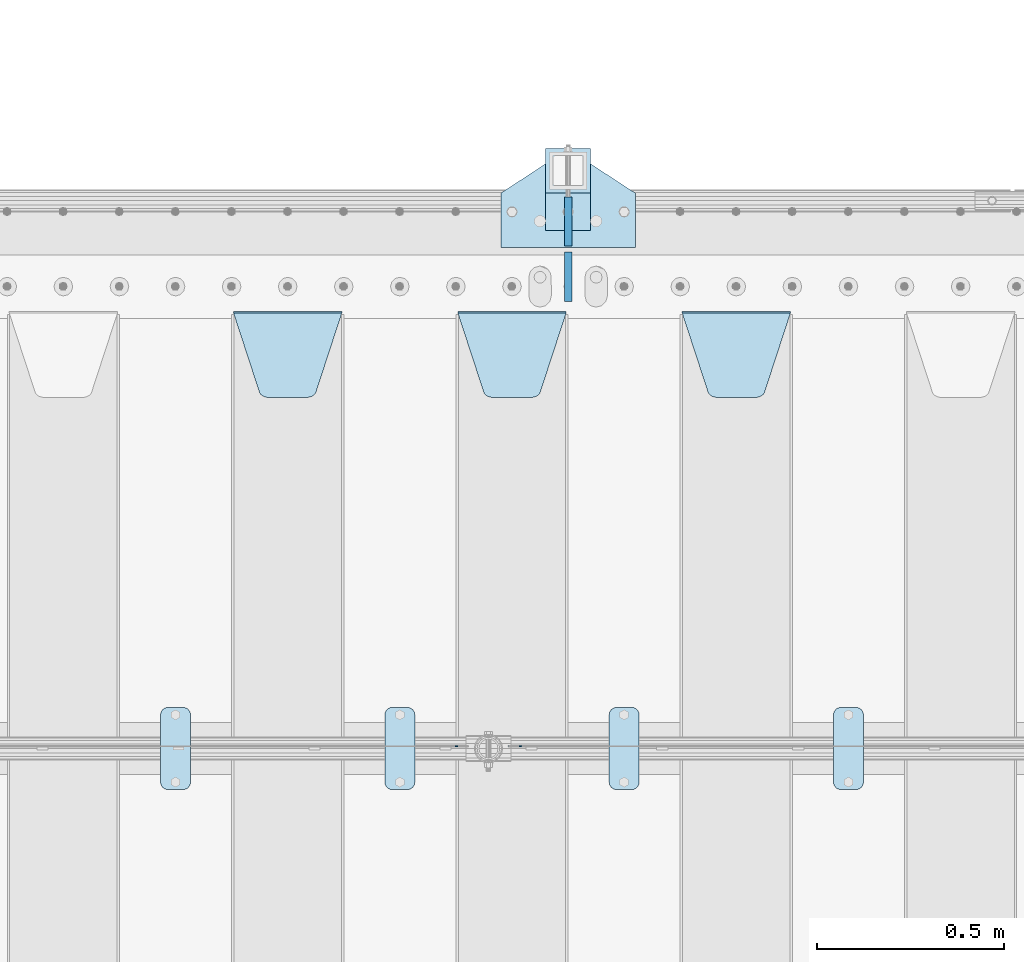
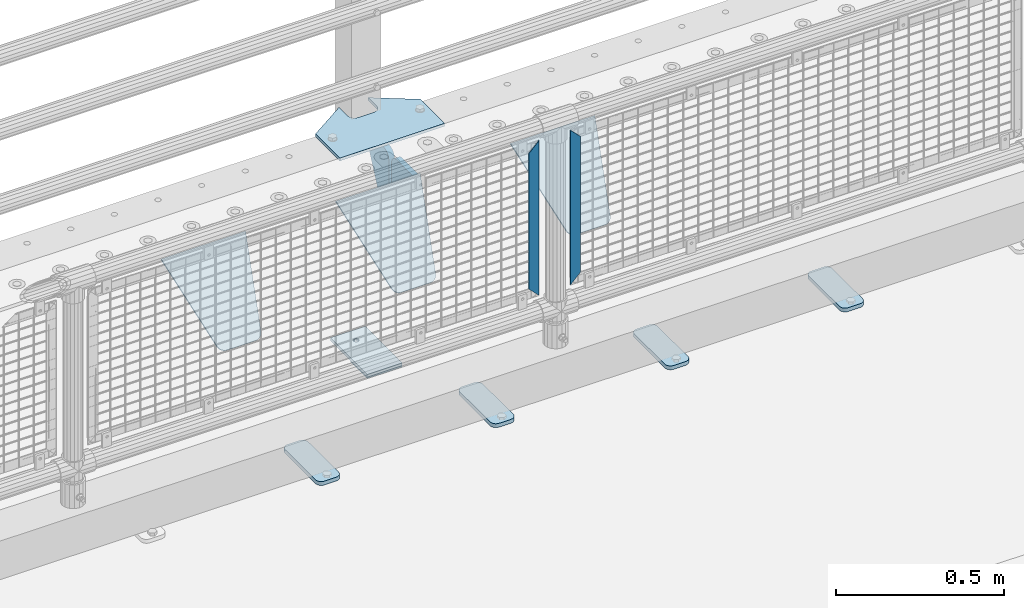
# One storey, part 196 of 219: 14 plates.
"""IFC2X3 building model written with IfcOpenShell, lengths in millimetres."""

import ifcopenshell
import ifcopenshell.guid

model = None  # the IFC model being written
_history = None  # IfcOwnerHistory: only IFC2X3 demands one
_inside = {}  # id of a spatial element -> (the spatial element, [elements in it])
_under = {}  # id of a project, library or spatial element -> (it, [spatial elements below it])
_declared = {}  # id of a project -> (the project, [libraries it declares])
_typed = {}  # id of a type object -> (the type object, [elements of that type])
_made_of = {}  # id of a material, layer set ... -> (it, [elements and type objects made of it])


def new_model(schema):
    """Start an empty IFC model of exactly this schema.

    Asked for "IFC4X3", IfcOpenShell would pick the latest addendum, in which some entities
    have other attributes; the version numbers below select the first issue.
    IFC2X3 requires an IfcOwnerHistory on every rooted entity: one is made here for all.
    """
    global model, _history
    if schema == "IFC4X3":
        model = ifcopenshell.file(schema_version=(4, 3, 0, 0))
    else:
        model = ifcopenshell.file(schema=schema)
    _inside.clear()
    _under.clear()
    _declared.clear()
    _typed.clear()
    _made_of.clear()
    _history = None
    if model.schema == "IFC2X3":
        org = make("IfcOrganization", Name="unknown")
        user = make(
            "IfcPersonAndOrganization",
            ThePerson=make("IfcPerson", FamilyName="unknown"),
            TheOrganization=org,
        )
        app = make(
            "IfcApplication",
            ApplicationDeveloper=org,
            Version="unknown",
            ApplicationFullName="unknown",
            ApplicationIdentifier="unknown",
        )
        _history = make(
            "IfcOwnerHistory",
            OwningUser=user,
            OwningApplication=app,
            ChangeAction="ADDED",
            CreationDate=0,
        )
    return model


def make(cls, **values):
    """One entity of the class cls with the attributes given. An attribute that is None is left unset."""
    return model.create_entity(
        cls, **{name: value for name, value in values.items() if value is not None}
    )


def rooted(cls, **values):
    """An entity with a GlobalId (a new one), such as an element, a storey or a relation."""
    return make(cls, GlobalId=ifcopenshell.guid.new(), OwnerHistory=_history, **values)


def si_unit(unit_type, name, prefix=None):
    """IfcSIUnit, for example si_unit("LENGTHUNIT", "METRE", prefix="MILLI")."""
    return make("IfcSIUnit", UnitType=unit_type, Prefix=prefix, Name=name)


def assignment(units):
    """IfcUnitAssignment: the units of a project."""
    return None if units is None else make("IfcUnitAssignment", Units=units)


def point(xyz):
    """IfcCartesianPoint."""
    return None if xyz is None else make("IfcCartesianPoint", Coordinates=xyz)


def direction(xyz):
    """IfcDirection."""
    return None if xyz is None else make("IfcDirection", DirectionRatios=xyz)


def frame(location, z_axis=None, x_axis=None):
    """IfcAxis2Placement3D, a coordinate frame: its origin and axes. An axis left out is left unset."""
    return make(
        "IfcAxis2Placement3D",
        Location=point(location),
        Axis=direction(z_axis),
        RefDirection=direction(x_axis),
    )


def origin_with_axes():
    """The frame at (0, 0, 0) with the z axis (0, 0, 1) and the x axis (1, 0, 0) written out."""
    return frame((0.0, 0.0, 0.0), z_axis=(0.0, 0.0, 1.0), x_axis=(1.0, 0.0, 0.0))


def place(relative_to, where):
    """IfcLocalPlacement: puts the frame where relative to a parent placement (None: the world)."""
    return make(
        "IfcLocalPlacement", PlacementRelTo=relative_to, RelativePlacement=where
    )


def context(
    kind, dimensions, precision=None, world=None, true_north=None, identifier=None
):
    """IfcGeometricRepresentationContext, for example the 3D "Model" context."""
    return make(
        "IfcGeometricRepresentationContext",
        ContextIdentifier=identifier,
        ContextType=kind,
        CoordinateSpaceDimension=dimensions,
        Precision=precision,
        WorldCoordinateSystem=world,
        TrueNorth=true_north,
    )


def subcontext(parent, identifier, kind, view, scale=None):
    """IfcGeometricRepresentationSubContext, for example "Body" below "Model"."""
    return make(
        "IfcGeometricRepresentationSubContext",
        ContextIdentifier=identifier,
        ContextType=kind,
        ParentContext=parent,
        TargetScale=scale,
        TargetView=view,
    )


def project(units=None, contexts=None):
    """IfcProject with its units and contexts."""
    return rooted(
        "IfcProject",
        Name="project",
        RepresentationContexts=contexts,
        UnitsInContext=assignment(units),
    )


def spatial(cls, under=None, at=None, **own):
    """A site, building, storey or space (cls), placed at a placement, below another one or the project."""
    s = rooted(cls, ObjectPlacement=at, **own)
    if under is not None:
        _under.setdefault(under.id(), (under, []))[1].append(s)
    return s


def faces_of(points, faces, orient=None, outer=None):
    """IfcFace entities. A face is a list of loops; a loop is a list of indices into points, from 0.

    orient and outer hold one flag for each loop. By default every Orientation is true, the
    first loop of a face is its IfcFaceOuterBound and the others are IfcFaceBound.
    """
    made = []
    for i, loops in enumerate(faces):
        bounds = []
        for j, loop in enumerate(loops):
            is_outer = j == 0 if outer is None else outer[i][j]
            bounds.append(
                make(
                    "IfcFaceOuterBound" if is_outer else "IfcFaceBound",
                    Bound=make("IfcPolyLoop", Polygon=[points[k] for k in loop]),
                    Orientation=True if orient is None else orient[i][j],
                )
            )
        made.append(make("IfcFace", Bounds=bounds))
    return made


def faceted_brep(points, faces, orient=None, outer=None, voids=None):
    """IfcFacetedBrep: a solid bounded by flat faces; with voids (closed shells), ...WithVoids."""
    shared = [point(p) for p in points]
    hull = make("IfcClosedShell", CfsFaces=faces_of(shared, faces, orient, outer))
    if voids is None:
        return make("IfcFacetedBrep", Outer=hull)
    return make(
        "IfcFacetedBrepWithVoids",
        Outer=hull,
        Voids=[
            make(cls, CfsFaces=faces_of(shared, fs, o, b)) for cls, fs, o, b in voids
        ],
    )


def shape(context_of_items, identifier, shape_type, items):
    """IfcShapeRepresentation: the items that make up one representation, for example the "Body"."""
    return make(
        "IfcShapeRepresentation",
        ContextOfItems=context_of_items,
        RepresentationIdentifier=identifier,
        RepresentationType=shape_type,
        Items=items,
    )


def material(Name=None, Category=None):
    """IfcMaterial."""
    return make("IfcMaterial", Name=Name, Category=Category)


def made_of(thing, what):
    """Note that an element or type object is made of a material, layer set ...; save() writes the relation."""
    if what is not None:
        _made_of.setdefault(what.id(), (what, []))[1].append(thing)
    return thing


def type_object(cls, material=None, **own):
    """A type object (cls), such as IfcWallType, which elements share."""
    return made_of(rooted(cls, **own), material)


def element(
    cls,
    number,
    at=None,
    inside=None,
    cuts=None,
    type_object=None,
    material=None,
    context=None,
    identifier="Body",
    shape_type=None,
    held_by="IfcProductDefinitionShape",
    body=None,
    shapes=None,
    **own,
):
    """One element of the class cls, such as IfcWall. Its Tag is "e" and its number.

    at: its placement. inside: the storey or other place that contains it. cuts: it is an
    opening in that element (IfcRelVoidsElement). A single representation is given by context,
    identifier, shape_type and body (its items); several are given by shapes. held_by: the class
    of the entity that holds the representations. save() writes the other relations.
    """
    e = rooted(cls, Tag="e%d" % number, ObjectPlacement=at, **own)
    if body is not None:
        shapes = [shape(context, identifier, shape_type, body)]
    if shapes is not None:
        e.Representation = make(held_by, Representations=shapes)
    if inside is not None:
        _inside.setdefault(inside.id(), (inside, []))[1].append(e)
    if cuts is not None:
        rooted(
            "IfcRelVoidsElement", RelatingBuildingElement=cuts, RelatedOpeningElement=e
        )
    if type_object is not None:
        _typed.setdefault(type_object.id(), (type_object, []))[1].append(e)
    return made_of(e, material)


def aggregate(whole, parts):
    """IfcRelAggregates: a whole, such as a stair, and the parts it consists of."""
    return rooted("IfcRelAggregates", RelatingObject=whole, RelatedObjects=parts)


def save(model, path):
    """Write the relations noted so far, then the file.

    IfcRelAggregates (storeys below a building ...), IfcRelContainedInSpatialStructure (elements
    in a storey), IfcRelDefinesByType, IfcRelAssociatesMaterial and IfcRelDeclares: one each for
    every whole, place, type object, material and project.
    """
    for whole, parts in _under.values():
        aggregate(whole, parts)
    for where, things in _inside.values():
        rooted(
            "IfcRelContainedInSpatialStructure",
            RelatedElements=things,
            RelatingStructure=where,
        )
    for kind, things in _typed.values():
        rooted("IfcRelDefinesByType", RelatedObjects=things, RelatingType=kind)
    for what, things in _made_of.values():
        rooted("IfcRelAssociatesMaterial", RelatedObjects=things, RelatingMaterial=what)
    for by, libraries in _declared.values():
        rooted("IfcRelDeclares", RelatingContext=by, RelatedDefinitions=libraries)
    model.write(path)


model = new_model("IFC2X3")

# Units and contexts
model_context = context("Model", 3, precision=1e-05, world=origin_with_axes())
body_context = subcontext(model_context, "Body", "Model", "MODEL_VIEW")
ifc_project = project(units=[si_unit("LENGTHUNIT", "METRE", prefix="MILLI"), si_unit("AREAUNIT", "SQUARE_METRE"), si_unit("VOLUMEUNIT", "CUBIC_METRE"), si_unit("MASSUNIT", "GRAM", prefix="KILO"), si_unit("TIMEUNIT", "SECOND"), si_unit("PLANEANGLEUNIT", "RADIAN"), si_unit("SOLIDANGLEUNIT", "STERADIAN"), si_unit("THERMODYNAMICTEMPERATUREUNIT", "DEGREE_CELSIUS"), si_unit("LUMINOUSINTENSITYUNIT", "LUMEN")], contexts=[model_context])

# Site, building, storey
site_placement = place(None, origin_with_axes())
site = spatial("IfcSite", under=ifc_project, at=site_placement, CompositionType="ELEMENT")
building_placement = place(site_placement, origin_with_axes())
building = spatial("IfcBuilding", under=site, at=building_placement, Name="Standard", CompositionType="ELEMENT")
storey_placement = place(building_placement, origin_with_axes())
storey = spatial("IfcBuildingStorey", under=building, at=storey_placement, Name="Undefined", CompositionType="ELEMENT", Elevation=0.0)

# Plates
ifc_material_1 = material(Name="STEEL/S355N")
plate_type_1 = type_object("IfcPlateType", PredefinedType="NOTDEFINED")
plate_1_placement = place(storey_placement, frame((4455.0, 32831.767766956, -1.76776695296758), z_axis=(0.0, -0.707106781186547, -0.707106781186548), x_axis=(1.0, 0.0, 0.0)))
element("IfcPlate", 1, at=plate_1_placement, inside=storey, type_object=plate_type_1, material=ifc_material_1, context=body_context, shape_type="Brep", body=[
    faceted_brep([(0.0, -2.5, 0.0), (69.345504679477, -2.5, 300.171731424834), (69.345504679477, 2.49999999999636, 300.171731424831), (0.0, 2.5, 0.0), (70.9274061199576, -2.50000000000364, 304.8974424154), (70.9274061199576, 2.49999999999636, 304.8974424154), (73.3818627772307, -2.50000000000364, 309.234538108532), (73.3818627772307, 2.49999999999636, 309.234538108532), (76.6187032999569, -2.50000000000364, 313.023683126106), (76.6187032999569, 2.49999999999636, 313.023683126106), (80.5190132704993, -2.50000000000364, 316.125672595372), (80.5190132704993, 2.49999999999636, 316.125672595372), (84.9395038596831, -2.50000000000364, 318.426546230476), (84.9395038596831, 2.5, 318.426546230479), (89.7177759439237, -2.50000000000364, 319.841774983277), (89.7177759439237, 2.5, 319.841774983281), (94.6782862926502, -2.50000000000364, 320.319366455078), (94.6782862926502, 2.49999999999636, 320.319366455078), (195.32171370735, -2.50000000000364, 320.319366455078), (195.32171370735, 2.49999999999636, 320.319366455078), (200.282224056076, -2.50000000000364, 319.841774983277), (200.282224056076, 2.5, 319.841774983281), (205.060496140317, -2.50000000000364, 318.426546230476), (205.060496140317, 2.49999999999636, 318.426546230476), (209.480986729501, -2.50000000000364, 316.125672595372), (209.480986729501, 2.49999999999636, 316.125672595372), (213.381296700043, -2.50000000000364, 313.023683126106), (213.381296700043, 2.49999999999272, 313.023683126106), (216.618137222769, -2.50000000000364, 309.234538108529), (216.618137222769, 2.49999999999636, 309.234538108525), (219.072593880042, -2.50000000000364, 304.8974424154), (219.072593880042, 2.49999999999636, 304.8974424154), (220.654495320523, -2.5, 300.171731424834), (220.654495320523, 2.49999999999636, 300.171731424831), (290.0, -2.50000000000364, 3.63797880709171e-12), (290.0, 2.49999999999636, 0.0)], [[[0, 1, 2, 3]], [[1, 4, 5, 2]], [[4, 6, 7, 5]], [[6, 8, 9, 7]], [[8, 10, 11, 9]], [[10, 12, 13, 11]], [[12, 14, 15, 13]], [[14, 16, 17, 15]], [[16, 18, 19, 17]], [[18, 20, 21, 19]], [[20, 22, 23, 21]], [[22, 24, 25, 23]], [[24, 26, 27, 25]], [[26, 28, 29, 27]], [[28, 30, 31, 29]], [[30, 32, 33, 31]], [[32, 34, 35, 33]], [[34, 0, 3, 35]], [[5, 7, 9, 11, 13, 15, 17, 19, 21, 23, 25, 27, 29, 31, 33, 35, 3, 2]], [[34, 32, 30, 28, 26, 24, 22, 20, 18, 16, 14, 12, 10, 8, 6, 4, 1, 0]]]),
])
plate_2_placement = place(storey_placement, frame((3855.0, 32831.767766956, -1.76776695296758), z_axis=(0.0, -0.707106781186547, -0.707106781186548), x_axis=(1.0, 0.0, 0.0)))
element("IfcPlate", 2, at=plate_2_placement, inside=storey, type_object=plate_type_1, material=ifc_material_1, context=body_context, shape_type="Brep", body=[
    faceted_brep([(0.0, -2.5, 0.0), (69.345504679477, -2.5, 300.171731424834), (69.345504679477, 2.49999999999636, 300.171731424831), (0.0, 2.5, 0.0), (70.9274061199576, -2.50000000000364, 304.8974424154), (70.9274061199576, 2.49999999999636, 304.8974424154), (73.3818627772307, -2.50000000000364, 309.234538108532), (73.3818627772307, 2.49999999999636, 309.234538108532), (76.6187032999569, -2.50000000000364, 313.023683126106), (76.6187032999569, 2.49999999999636, 313.023683126106), (80.5190132704993, -2.50000000000364, 316.125672595372), (80.5190132704993, 2.49999999999636, 316.125672595372), (84.9395038596831, -2.50000000000364, 318.426546230476), (84.9395038596831, 2.5, 318.426546230479), (89.7177759439237, -2.50000000000364, 319.841774983277), (89.7177759439237, 2.5, 319.841774983281), (94.6782862926502, -2.50000000000364, 320.319366455078), (94.6782862926502, 2.49999999999636, 320.319366455078), (195.32171370735, -2.50000000000364, 320.319366455078), (195.32171370735, 2.49999999999636, 320.319366455078), (200.282224056076, -2.50000000000364, 319.841774983277), (200.282224056076, 2.5, 319.841774983281), (205.060496140317, -2.50000000000364, 318.426546230476), (205.060496140317, 2.49999999999636, 318.426546230476), (209.480986729501, -2.50000000000364, 316.125672595372), (209.480986729501, 2.49999999999636, 316.125672595372), (213.381296700043, -2.50000000000364, 313.023683126106), (213.381296700043, 2.49999999999272, 313.023683126106), (216.618137222769, -2.50000000000364, 309.234538108529), (216.618137222769, 2.49999999999636, 309.234538108525), (219.072593880042, -2.50000000000364, 304.8974424154), (219.072593880042, 2.49999999999636, 304.8974424154), (220.654495320523, -2.5, 300.171731424834), (220.654495320523, 2.49999999999636, 300.171731424831), (290.0, -2.50000000000364, 3.63797880709171e-12), (290.0, 2.49999999999636, 0.0)], [[[0, 1, 2, 3]], [[1, 4, 5, 2]], [[4, 6, 7, 5]], [[6, 8, 9, 7]], [[8, 10, 11, 9]], [[10, 12, 13, 11]], [[12, 14, 15, 13]], [[14, 16, 17, 15]], [[16, 18, 19, 17]], [[18, 20, 21, 19]], [[20, 22, 23, 21]], [[22, 24, 25, 23]], [[24, 26, 27, 25]], [[26, 28, 29, 27]], [[28, 30, 31, 29]], [[30, 32, 33, 31]], [[32, 34, 35, 33]], [[34, 0, 3, 35]], [[5, 7, 9, 11, 13, 15, 17, 19, 21, 23, 25, 27, 29, 31, 33, 35, 3, 2]], [[34, 32, 30, 28, 26, 24, 22, 20, 18, 16, 14, 12, 10, 8, 6, 4, 1, 0]]]),
])
plate_3_placement = place(storey_placement, frame((3255.0, 32831.767766956, -1.76776695296758), z_axis=(0.0, -0.707106781186547, -0.707106781186548), x_axis=(1.0, 0.0, 0.0)))
element("IfcPlate", 3, at=plate_3_placement, inside=storey, type_object=plate_type_1, material=ifc_material_1, context=body_context, shape_type="Brep", body=[
    faceted_brep([(0.0, -2.5, 0.0), (69.345504679477, -2.5, 300.171731424834), (69.345504679477, 2.49999999999636, 300.171731424831), (0.0, 2.5, 0.0), (70.9274061199576, -2.50000000000364, 304.8974424154), (70.9274061199576, 2.49999999999636, 304.8974424154), (73.3818627772307, -2.50000000000364, 309.234538108532), (73.3818627772307, 2.49999999999636, 309.234538108532), (76.6187032999569, -2.50000000000364, 313.023683126106), (76.6187032999569, 2.49999999999636, 313.023683126106), (80.5190132704993, -2.50000000000364, 316.125672595372), (80.5190132704993, 2.49999999999636, 316.125672595372), (84.9395038596831, -2.50000000000364, 318.426546230476), (84.9395038596831, 2.5, 318.426546230479), (89.7177759439237, -2.50000000000364, 319.841774983277), (89.7177759439237, 2.5, 319.841774983281), (94.6782862926502, -2.50000000000364, 320.319366455078), (94.6782862926502, 2.49999999999636, 320.319366455078), (195.32171370735, -2.50000000000364, 320.319366455078), (195.32171370735, 2.49999999999636, 320.319366455078), (200.282224056076, -2.50000000000364, 319.841774983277), (200.282224056076, 2.5, 319.841774983281), (205.060496140317, -2.50000000000364, 318.426546230476), (205.060496140317, 2.49999999999636, 318.426546230476), (209.480986729501, -2.50000000000364, 316.125672595372), (209.480986729501, 2.49999999999636, 316.125672595372), (213.381296700043, -2.50000000000364, 313.023683126106), (213.381296700043, 2.49999999999272, 313.023683126106), (216.618137222769, -2.50000000000364, 309.234538108529), (216.618137222769, 2.49999999999636, 309.234538108525), (219.072593880042, -2.50000000000364, 304.8974424154), (219.072593880042, 2.49999999999636, 304.8974424154), (220.654495320523, -2.5, 300.171731424834), (220.654495320523, 2.49999999999636, 300.171731424831), (290.0, -2.50000000000364, 3.63797880709171e-12), (290.0, 2.49999999999636, 0.0)], [[[0, 1, 2, 3]], [[1, 4, 5, 2]], [[4, 6, 7, 5]], [[6, 8, 9, 7]], [[8, 10, 11, 9]], [[10, 12, 13, 11]], [[12, 14, 15, 13]], [[14, 16, 17, 15]], [[16, 18, 19, 17]], [[18, 20, 21, 19]], [[20, 22, 23, 21]], [[22, 24, 25, 23]], [[24, 26, 27, 25]], [[26, 28, 29, 27]], [[28, 30, 31, 29]], [[30, 32, 33, 31]], [[32, 34, 35, 33]], [[34, 0, 3, 35]], [[5, 7, 9, 11, 13, 15, 17, 19, 21, 23, 25, 27, 29, 31, 33, 35, 3, 2]], [[34, 32, 30, 28, 26, 24, 22, 20, 18, 16, 14, 12, 10, 8, 6, 4, 1, 0]]]),
])
ifc_material_2 = material(Name="Misc_Undefined")
plate_type_2 = type_object("IfcPlateType", PredefinedType="NOTDEFINED")
plate_4_placement = place(storey_placement, frame((4025.50971354097, 31670.5, 879.519963133601), z_axis=(-0.707008801899319, 0.0, -0.707204746899291), x_axis=(-0.707204746899285, 0.0, 0.707008801899324)))
element("IfcPlate", 4, at=plate_4_placement, inside=storey, type_object=plate_type_2, material=ifc_material_2, context=body_context, shape_type="Brep", body=[
    faceted_brep([(0.0, -1.5, -5.6843418860808e-14), (-348.552185058593, -1.5, 348.655029296875), (-348.552185058593, 1.5, 348.655029296875), (0.0, 1.5, -5.6843418860808e-14), (-348.544891357421, -1.5, 398.152496337892), (-348.544891357421, 1.5, 398.152496337892), (49.5043945312482, -1.5, 7.6397554948926e-11), (49.5043945312482, 1.5, 7.6397554948926e-11)], [[[0, 1, 2, 3]], [[1, 4, 5, 2]], [[4, 6, 7, 5]], [[6, 0, 3, 7]], [[5, 7, 3, 2]], [[6, 4, 1, 0]]]),
])
plate_5_placement = place(storey_placement, frame((3848.49968748361, 31670.5, 879.52), z_axis=(0.707103624179499, 0.0, -0.707109938179501), x_axis=(0.707109938179499, 0.0, 0.707103624179502)))
element("IfcPlate", 5, at=plate_5_placement, inside=storey, type_object=plate_type_2, material=ifc_material_2, context=body_context, shape_type="Brep", body=[
    faceted_brep([(0.0, -1.5, -5.6843418860808e-14), (-348.605163574219, -1.5, 348.602081298829), (-348.605163574219, 1.5, 348.602081298829), (0.0, 1.5, -5.6843418860808e-14), (-348.605163574217, -1.5, 398.0993347168), (-348.605163574217, 1.5, 398.0993347168), (49.4976959228516, -1.5, -1.0550138540566e-10), (49.4976959228516, 1.5, -1.0550138540566e-10)], [[[0, 1, 2, 3]], [[1, 4, 5, 2]], [[4, 6, 7, 5]], [[6, 0, 3, 7]], [[5, 7, 3, 2]], [[6, 4, 1, 0]]]),
])
plate_type_3 = type_object("IfcPlateType", PredefinedType="NOTDEFINED")
for number, where, z_axis, x_axis in (
    (6, (4150.0, 32860.0, -30.0), (0.0, 0.0, -1.0), (0.0, 1.0, 0.0)),
    (7, (4150.0, 33140.0, -30.0), (0.0, 0.0, -1.0), (0.0, -1.0, 0.0)),
):
    element("IfcPlate", number, at=place(storey_placement, frame(where, z_axis=z_axis, x_axis=x_axis)), inside=storey, type_object=plate_type_3, material=ifc_material_1, context=body_context, shape_type="Brep", body=[
        faceted_brep([(0.0, -10.0, 0.0), (0.0, -10.0, 30.0), (0.0, 10.0, 30.0), (0.0, 10.0, 0.0), (102.0, -10.0, 250.0), (102.0, 10.0, 250.0), (132.0, -10.0, 250.0), (132.0, 10.0, 250.0), (132.0, -10.0, 30.0), (132.0, 10.0, 30.0), (131.544232590368, -10.0, 24.790554669992), (131.544232590368, 10.0, 24.790554669992), (130.190778623579, -10.0, 19.7393957002299), (130.190778623579, 10.0, 19.7393957002299), (127.980762113533, -10.0, 15.0), (127.980762113533, 10.0, 15.0), (124.98133329357, -10.0, 10.7163717094038), (124.98133329357, 10.0, 10.7163717094038), (121.283628290596, -10.0, 7.01866670643062), (121.283628290596, 10.0, 7.01866670643062), (117.0, -10.0, 4.01923788646684), (117.0, 10.0, 4.01923788646684), (112.260604299769, -10.0, 1.80922137642278), (112.260604299769, 10.0, 1.80922137642278), (107.209445330009, -10.0, 0.455767409633722), (107.209445330009, 10.0, 0.455767409633722), (102.0, -10.0, 0.0), (102.0, 10.0, 0.0)], [[[0, 1, 2, 3]], [[1, 4, 5, 2]], [[4, 6, 7, 5]], [[6, 8, 9, 7]], [[8, 10, 11, 9]], [[10, 12, 13, 11]], [[12, 14, 15, 13]], [[14, 16, 17, 15]], [[16, 18, 19, 17]], [[18, 20, 21, 19]], [[20, 22, 23, 21]], [[22, 24, 25, 23]], [[24, 26, 27, 25]], [[26, 0, 3, 27]], [[5, 7, 9, 11, 13, 15, 17, 19, 21, 23, 25, 27, 3, 2]], [[26, 24, 22, 20, 18, 16, 14, 12, 10, 8, 6, 4, 1, 0]]]),
    ])
ifc_material_3 = material(Name="STEEL/S355J2")
plate_type_4 = type_object("IfcPlateType", PredefinedType="NOTDEFINED")
plate_6_placement = place(storey_placement, frame((4860.0, 31774.5, 21.0199999999977), z_axis=(1.0, 0.0, 0.0), x_axis=(0.0, -1.0, 0.0)))
element("IfcPlate", 8, at=plate_6_placement, inside=storey, type_object=plate_type_4, material=ifc_material_3, context=body_context, shape_type="Brep", body=[
    faceted_brep([(0.0, -7.0, 20.0), (0.0, -7.0, 60.0), (0.0, 7.0, 60.0), (0.0, 7.0, 20.0), (0.384294391937146, -7.0, 63.9018064403226), (0.384294391937146, 7.0, 63.9018064403226), (1.52240934977453, -7.0, 67.6536686473009), (1.52240934977453, 7.0, 67.6536686473009), (3.37060775395003, -7.0, 71.1114046603925), (3.37060775395003, 7.0, 71.1114046603925), (5.8578643762703, -7.0, 74.1421356237315), (5.8578643762703, 7.0, 74.1421356237315), (8.88859533960931, -7.0, 76.6293922460518), (8.88859533960931, 7.0, 76.6293922460518), (12.3463313526991, -7.0, 78.4775906502255), (12.3463313526991, 7.0, 78.4775906502255), (16.0981935596792, -7.0, 79.6157056080647), (16.0981935596792, 7.0, 79.6157056080647), (20.0, -7.0, 80.0), (20.0, 7.0, 80.0), (200.0, -7.0, 80.0), (200.0, 7.0, 80.0), (203.901806440321, -7.0, 79.6157056080647), (203.901806440321, 7.0, 79.6157056080647), (207.653668647301, -7.0, 78.4775906502255), (207.653668647301, 7.0, 78.4775906502255), (211.111404660391, -7.0, 76.6293922460518), (211.111404660391, 7.0, 76.6293922460518), (214.14213562373, -7.0, 74.1421356237315), (214.14213562373, 7.0, 74.1421356237315), (216.62939224605, -7.0, 71.1114046603925), (216.62939224605, 7.0, 71.1114046603925), (218.477590650225, -7.0, 67.6536686473009), (218.477590650225, 7.0, 67.6536686473009), (219.615705608063, -7.0, 63.9018064403226), (219.615705608063, 7.0, 63.9018064403226), (220.0, -7.0, 60.0), (220.0, 7.0, 60.0), (220.0, -7.0, 20.0), (220.0, 7.0, 20.0), (219.615705608063, -7.0, 16.0981935596774), (219.615705608063, 7.0, 16.0981935596774), (218.477590650225, -7.0, 12.3463313526991), (218.477590650225, 7.0, 12.3463313526991), (216.62939224605, -7.0, 8.88859533960749), (216.62939224605, 7.0, 8.88859533960749), (214.14213562373, -7.0, 5.85786437626848), (214.14213562373, 7.0, 5.85786437626848), (211.111404660391, -7.0, 3.37060775394821), (211.111404660391, 7.0, 3.37060775394821), (207.653668647301, -7.0, 1.52240934977453), (207.653668647301, 7.0, 1.52240934977453), (203.901806440321, -7.0, 0.384294391935327), (203.901806440321, 7.0, 0.384294391935327), (200.0, -7.0, 0.0), (200.0, 7.0, 0.0), (20.0, -7.0, 0.0), (20.0, 7.0, 0.0), (16.0981935596792, -7.0, 0.384294391935327), (16.0981935596792, 7.0, 0.384294391935327), (12.3463313526991, -7.0, 1.52240934977453), (12.3463313526991, 7.0, 1.52240934977453), (8.88859533960931, -7.0, 3.37060775394821), (8.88859533960931, 7.0, 3.37060775394821), (5.8578643762703, -7.0, 5.85786437626848), (5.8578643762703, 7.0, 5.85786437626848), (3.37060775395003, -7.0, 8.88859533960749), (3.37060775395003, 7.0, 8.88859533960749), (1.52240934977453, -7.0, 12.3463313526991), (1.52240934977453, 7.0, 12.3463313526991), (0.384294391937146, -7.0, 16.0981935596774), (0.384294391937146, 7.0, 16.0981935596774)], [[[0, 1, 2, 3]], [[1, 4, 5, 2]], [[4, 6, 7, 5]], [[6, 8, 9, 7]], [[8, 10, 11, 9]], [[10, 12, 13, 11]], [[12, 14, 15, 13]], [[14, 16, 17, 15]], [[16, 18, 19, 17]], [[18, 20, 21, 19]], [[20, 22, 23, 21]], [[22, 24, 25, 23]], [[24, 26, 27, 25]], [[26, 28, 29, 27]], [[28, 30, 31, 29]], [[30, 32, 33, 31]], [[32, 34, 35, 33]], [[34, 36, 37, 35]], [[36, 38, 39, 37]], [[38, 40, 41, 39]], [[40, 42, 43, 41]], [[42, 44, 45, 43]], [[44, 46, 47, 45]], [[46, 48, 49, 47]], [[48, 50, 51, 49]], [[50, 52, 53, 51]], [[52, 54, 55, 53]], [[54, 56, 57, 55]], [[56, 58, 59, 57]], [[58, 60, 61, 59]], [[60, 62, 63, 61]], [[62, 64, 65, 63]], [[64, 66, 67, 65]], [[66, 68, 69, 67]], [[68, 70, 71, 69]], [[70, 0, 3, 71]], [[5, 7, 9, 11, 13, 15, 17, 19, 21, 23, 25, 27, 29, 31, 33, 35, 37, 39, 41, 43, 45, 47, 49, 51, 53, 55, 57, 59, 61, 63, 65, 67, 69, 71, 3, 2]], [[70, 68, 66, 64, 62, 60, 58, 56, 54, 52, 50, 48, 46, 44, 42, 40, 38, 36, 34, 32, 30, 28, 26, 24, 22, 20, 18, 16, 14, 12, 10, 8, 6, 4, 1, 0]]]),
])
plate_7_placement = place(storey_placement, frame((4260.0, 31774.5, 21.0199999999977), z_axis=(1.0, 0.0, 0.0), x_axis=(0.0, -1.0, 0.0)))
element("IfcPlate", 9, at=plate_7_placement, inside=storey, type_object=plate_type_4, material=ifc_material_3, context=body_context, shape_type="Brep", body=[
    faceted_brep([(0.0, -7.0, 20.0), (0.0, -7.0, 60.0), (0.0, 7.0, 60.0), (0.0, 7.0, 20.0), (0.384294391937146, -7.0, 63.9018064403226), (0.384294391937146, 7.0, 63.9018064403226), (1.52240934977453, -7.0, 67.6536686473009), (1.52240934977453, 7.0, 67.6536686473009), (3.37060775395003, -7.0, 71.1114046603925), (3.37060775395003, 7.0, 71.1114046603925), (5.8578643762703, -7.0, 74.1421356237315), (5.8578643762703, 7.0, 74.1421356237315), (8.88859533960931, -7.0, 76.6293922460518), (8.88859533960931, 7.0, 76.6293922460518), (12.3463313526991, -7.0, 78.4775906502255), (12.3463313526991, 7.0, 78.4775906502255), (16.0981935596792, -7.0, 79.6157056080647), (16.0981935596792, 7.0, 79.6157056080647), (20.0, -7.0, 80.0), (20.0, 7.0, 80.0), (200.0, -7.0, 80.0), (200.0, 7.0, 80.0), (203.901806440321, -7.0, 79.6157056080647), (203.901806440321, 7.0, 79.6157056080647), (207.653668647301, -7.0, 78.4775906502255), (207.653668647301, 7.0, 78.4775906502255), (211.111404660391, -7.0, 76.6293922460518), (211.111404660391, 7.0, 76.6293922460518), (214.14213562373, -7.0, 74.1421356237315), (214.14213562373, 7.0, 74.1421356237315), (216.62939224605, -7.0, 71.1114046603925), (216.62939224605, 7.0, 71.1114046603925), (218.477590650225, -7.0, 67.6536686473009), (218.477590650225, 7.0, 67.6536686473009), (219.615705608063, -7.0, 63.9018064403226), (219.615705608063, 7.0, 63.9018064403226), (220.0, -7.0, 60.0), (220.0, 7.0, 60.0), (220.0, -7.0, 20.0), (220.0, 7.0, 20.0), (219.615705608063, -7.0, 16.0981935596774), (219.615705608063, 7.0, 16.0981935596774), (218.477590650225, -7.0, 12.3463313526991), (218.477590650225, 7.0, 12.3463313526991), (216.62939224605, -7.0, 8.88859533960749), (216.62939224605, 7.0, 8.88859533960749), (214.14213562373, -7.0, 5.85786437626848), (214.14213562373, 7.0, 5.85786437626848), (211.111404660391, -7.0, 3.37060775394821), (211.111404660391, 7.0, 3.37060775394821), (207.653668647301, -7.0, 1.52240934977453), (207.653668647301, 7.0, 1.52240934977453), (203.901806440321, -7.0, 0.384294391935327), (203.901806440321, 7.0, 0.384294391935327), (200.0, -7.0, 0.0), (200.0, 7.0, 0.0), (20.0, -7.0, 0.0), (20.0, 7.0, 0.0), (16.0981935596792, -7.0, 0.384294391935327), (16.0981935596792, 7.0, 0.384294391935327), (12.3463313526991, -7.0, 1.52240934977453), (12.3463313526991, 7.0, 1.52240934977453), (8.88859533960931, -7.0, 3.37060775394821), (8.88859533960931, 7.0, 3.37060775394821), (5.8578643762703, -7.0, 5.85786437626848), (5.8578643762703, 7.0, 5.85786437626848), (3.37060775395003, -7.0, 8.88859533960749), (3.37060775395003, 7.0, 8.88859533960749), (1.52240934977453, -7.0, 12.3463313526991), (1.52240934977453, 7.0, 12.3463313526991), (0.384294391937146, -7.0, 16.0981935596774), (0.384294391937146, 7.0, 16.0981935596774)], [[[0, 1, 2, 3]], [[1, 4, 5, 2]], [[4, 6, 7, 5]], [[6, 8, 9, 7]], [[8, 10, 11, 9]], [[10, 12, 13, 11]], [[12, 14, 15, 13]], [[14, 16, 17, 15]], [[16, 18, 19, 17]], [[18, 20, 21, 19]], [[20, 22, 23, 21]], [[22, 24, 25, 23]], [[24, 26, 27, 25]], [[26, 28, 29, 27]], [[28, 30, 31, 29]], [[30, 32, 33, 31]], [[32, 34, 35, 33]], [[34, 36, 37, 35]], [[36, 38, 39, 37]], [[38, 40, 41, 39]], [[40, 42, 43, 41]], [[42, 44, 45, 43]], [[44, 46, 47, 45]], [[46, 48, 49, 47]], [[48, 50, 51, 49]], [[50, 52, 53, 51]], [[52, 54, 55, 53]], [[54, 56, 57, 55]], [[56, 58, 59, 57]], [[58, 60, 61, 59]], [[60, 62, 63, 61]], [[62, 64, 65, 63]], [[64, 66, 67, 65]], [[66, 68, 69, 67]], [[68, 70, 71, 69]], [[70, 0, 3, 71]], [[5, 7, 9, 11, 13, 15, 17, 19, 21, 23, 25, 27, 29, 31, 33, 35, 37, 39, 41, 43, 45, 47, 49, 51, 53, 55, 57, 59, 61, 63, 65, 67, 69, 71, 3, 2]], [[70, 68, 66, 64, 62, 60, 58, 56, 54, 52, 50, 48, 46, 44, 42, 40, 38, 36, 34, 32, 30, 28, 26, 24, 22, 20, 18, 16, 14, 12, 10, 8, 6, 4, 1, 0]]]),
])
plate_8_placement = place(storey_placement, frame((3660.0, 31774.5, 21.0199999999977), z_axis=(1.0, 0.0, 0.0), x_axis=(0.0, -1.0, 0.0)))
element("IfcPlate", 10, at=plate_8_placement, inside=storey, type_object=plate_type_4, material=ifc_material_3, context=body_context, shape_type="Brep", body=[
    faceted_brep([(0.0, -7.0, 20.0), (0.0, -7.0, 60.0), (0.0, 7.0, 60.0), (0.0, 7.0, 20.0), (0.384294391937146, -7.0, 63.9018064403226), (0.384294391937146, 7.0, 63.9018064403226), (1.52240934977453, -7.0, 67.6536686473009), (1.52240934977453, 7.0, 67.6536686473009), (3.37060775395003, -7.0, 71.1114046603925), (3.37060775395003, 7.0, 71.1114046603925), (5.8578643762703, -7.0, 74.1421356237315), (5.8578643762703, 7.0, 74.1421356237315), (8.88859533960931, -7.0, 76.6293922460518), (8.88859533960931, 7.0, 76.6293922460518), (12.3463313526991, -7.0, 78.4775906502255), (12.3463313526991, 7.0, 78.4775906502255), (16.0981935596792, -7.0, 79.6157056080647), (16.0981935596792, 7.0, 79.6157056080647), (20.0, -7.0, 80.0), (20.0, 7.0, 80.0), (200.0, -7.0, 80.0), (200.0, 7.0, 80.0), (203.901806440321, -7.0, 79.6157056080647), (203.901806440321, 7.0, 79.6157056080647), (207.653668647301, -7.0, 78.4775906502255), (207.653668647301, 7.0, 78.4775906502255), (211.111404660391, -7.0, 76.6293922460518), (211.111404660391, 7.0, 76.6293922460518), (214.14213562373, -7.0, 74.1421356237315), (214.14213562373, 7.0, 74.1421356237315), (216.62939224605, -7.0, 71.1114046603925), (216.62939224605, 7.0, 71.1114046603925), (218.477590650225, -7.0, 67.6536686473009), (218.477590650225, 7.0, 67.6536686473009), (219.615705608063, -7.0, 63.9018064403226), (219.615705608063, 7.0, 63.9018064403226), (220.0, -7.0, 60.0), (220.0, 7.0, 60.0), (220.0, -7.0, 20.0), (220.0, 7.0, 20.0), (219.615705608063, -7.0, 16.0981935596774), (219.615705608063, 7.0, 16.0981935596774), (218.477590650225, -7.0, 12.3463313526991), (218.477590650225, 7.0, 12.3463313526991), (216.62939224605, -7.0, 8.88859533960749), (216.62939224605, 7.0, 8.88859533960749), (214.14213562373, -7.0, 5.85786437626848), (214.14213562373, 7.0, 5.85786437626848), (211.111404660391, -7.0, 3.37060775394821), (211.111404660391, 7.0, 3.37060775394821), (207.653668647301, -7.0, 1.52240934977453), (207.653668647301, 7.0, 1.52240934977453), (203.901806440321, -7.0, 0.384294391935327), (203.901806440321, 7.0, 0.384294391935327), (200.0, -7.0, 0.0), (200.0, 7.0, 0.0), (20.0, -7.0, 0.0), (20.0, 7.0, 0.0), (16.0981935596792, -7.0, 0.384294391935327), (16.0981935596792, 7.0, 0.384294391935327), (12.3463313526991, -7.0, 1.52240934977453), (12.3463313526991, 7.0, 1.52240934977453), (8.88859533960931, -7.0, 3.37060775394821), (8.88859533960931, 7.0, 3.37060775394821), (5.8578643762703, -7.0, 5.85786437626848), (5.8578643762703, 7.0, 5.85786437626848), (3.37060775395003, -7.0, 8.88859533960749), (3.37060775395003, 7.0, 8.88859533960749), (1.52240934977453, -7.0, 12.3463313526991), (1.52240934977453, 7.0, 12.3463313526991), (0.384294391937146, -7.0, 16.0981935596774), (0.384294391937146, 7.0, 16.0981935596774)], [[[0, 1, 2, 3]], [[1, 4, 5, 2]], [[4, 6, 7, 5]], [[6, 8, 9, 7]], [[8, 10, 11, 9]], [[10, 12, 13, 11]], [[12, 14, 15, 13]], [[14, 16, 17, 15]], [[16, 18, 19, 17]], [[18, 20, 21, 19]], [[20, 22, 23, 21]], [[22, 24, 25, 23]], [[24, 26, 27, 25]], [[26, 28, 29, 27]], [[28, 30, 31, 29]], [[30, 32, 33, 31]], [[32, 34, 35, 33]], [[34, 36, 37, 35]], [[36, 38, 39, 37]], [[38, 40, 41, 39]], [[40, 42, 43, 41]], [[42, 44, 45, 43]], [[44, 46, 47, 45]], [[46, 48, 49, 47]], [[48, 50, 51, 49]], [[50, 52, 53, 51]], [[52, 54, 55, 53]], [[54, 56, 57, 55]], [[56, 58, 59, 57]], [[58, 60, 61, 59]], [[60, 62, 63, 61]], [[62, 64, 65, 63]], [[64, 66, 67, 65]], [[66, 68, 69, 67]], [[68, 70, 71, 69]], [[70, 0, 3, 71]], [[5, 7, 9, 11, 13, 15, 17, 19, 21, 23, 25, 27, 29, 31, 33, 35, 37, 39, 41, 43, 45, 47, 49, 51, 53, 55, 57, 59, 61, 63, 65, 67, 69, 71, 3, 2]], [[70, 68, 66, 64, 62, 60, 58, 56, 54, 52, 50, 48, 46, 44, 42, 40, 38, 36, 34, 32, 30, 28, 26, 24, 22, 20, 18, 16, 14, 12, 10, 8, 6, 4, 1, 0]]]),
])
plate_9_placement = place(storey_placement, frame((3060.0, 31774.5, 21.0199999999977), z_axis=(1.0, 0.0, 0.0), x_axis=(0.0, -1.0, 0.0)))
element("IfcPlate", 11, at=plate_9_placement, inside=storey, type_object=plate_type_4, material=ifc_material_3, context=body_context, shape_type="Brep", body=[
    faceted_brep([(0.0, -7.0, 20.0), (0.0, -7.0, 60.0), (0.0, 7.0, 60.0), (0.0, 7.0, 20.0), (0.384294391937146, -7.0, 63.9018064403226), (0.384294391937146, 7.0, 63.9018064403226), (1.52240934977453, -7.0, 67.6536686473009), (1.52240934977453, 7.0, 67.6536686473009), (3.37060775395003, -7.0, 71.1114046603925), (3.37060775395003, 7.0, 71.1114046603925), (5.8578643762703, -7.0, 74.1421356237315), (5.8578643762703, 7.0, 74.1421356237315), (8.88859533960931, -7.0, 76.6293922460518), (8.88859533960931, 7.0, 76.6293922460518), (12.3463313526991, -7.0, 78.4775906502255), (12.3463313526991, 7.0, 78.4775906502255), (16.0981935596792, -7.0, 79.6157056080647), (16.0981935596792, 7.0, 79.6157056080647), (20.0, -7.0, 80.0), (20.0, 7.0, 80.0), (200.0, -7.0, 80.0), (200.0, 7.0, 80.0), (203.901806440321, -7.0, 79.6157056080647), (203.901806440321, 7.0, 79.6157056080647), (207.653668647301, -7.0, 78.4775906502255), (207.653668647301, 7.0, 78.4775906502255), (211.111404660391, -7.0, 76.6293922460518), (211.111404660391, 7.0, 76.6293922460518), (214.14213562373, -7.0, 74.1421356237315), (214.14213562373, 7.0, 74.1421356237315), (216.62939224605, -7.0, 71.1114046603925), (216.62939224605, 7.0, 71.1114046603925), (218.477590650225, -7.0, 67.6536686473009), (218.477590650225, 7.0, 67.6536686473009), (219.615705608063, -7.0, 63.9018064403226), (219.615705608063, 7.0, 63.9018064403226), (220.0, -7.0, 60.0), (220.0, 7.0, 60.0), (220.0, -7.0, 20.0), (220.0, 7.0, 20.0), (219.615705608063, -7.0, 16.0981935596774), (219.615705608063, 7.0, 16.0981935596774), (218.477590650225, -7.0, 12.3463313526991), (218.477590650225, 7.0, 12.3463313526991), (216.62939224605, -7.0, 8.88859533960749), (216.62939224605, 7.0, 8.88859533960749), (214.14213562373, -7.0, 5.85786437626848), (214.14213562373, 7.0, 5.85786437626848), (211.111404660391, -7.0, 3.37060775394821), (211.111404660391, 7.0, 3.37060775394821), (207.653668647301, -7.0, 1.52240934977453), (207.653668647301, 7.0, 1.52240934977453), (203.901806440321, -7.0, 0.384294391935327), (203.901806440321, 7.0, 0.384294391935327), (200.0, -7.0, 0.0), (200.0, 7.0, 0.0), (20.0, -7.0, 0.0), (20.0, 7.0, 0.0), (16.0981935596792, -7.0, 0.384294391935327), (16.0981935596792, 7.0, 0.384294391935327), (12.3463313526991, -7.0, 1.52240934977453), (12.3463313526991, 7.0, 1.52240934977453), (8.88859533960931, -7.0, 3.37060775394821), (8.88859533960931, 7.0, 3.37060775394821), (5.8578643762703, -7.0, 5.85786437626848), (5.8578643762703, 7.0, 5.85786437626848), (3.37060775395003, -7.0, 8.88859533960749), (3.37060775395003, 7.0, 8.88859533960749), (1.52240934977453, -7.0, 12.3463313526991), (1.52240934977453, 7.0, 12.3463313526991), (0.384294391937146, -7.0, 16.0981935596774), (0.384294391937146, 7.0, 16.0981935596774)], [[[0, 1, 2, 3]], [[1, 4, 5, 2]], [[4, 6, 7, 5]], [[6, 8, 9, 7]], [[8, 10, 11, 9]], [[10, 12, 13, 11]], [[12, 14, 15, 13]], [[14, 16, 17, 15]], [[16, 18, 19, 17]], [[18, 20, 21, 19]], [[20, 22, 23, 21]], [[22, 24, 25, 23]], [[24, 26, 27, 25]], [[26, 28, 29, 27]], [[28, 30, 31, 29]], [[30, 32, 33, 31]], [[32, 34, 35, 33]], [[34, 36, 37, 35]], [[36, 38, 39, 37]], [[38, 40, 41, 39]], [[40, 42, 43, 41]], [[42, 44, 45, 43]], [[44, 46, 47, 45]], [[46, 48, 49, 47]], [[48, 50, 51, 49]], [[50, 52, 53, 51]], [[52, 54, 55, 53]], [[54, 56, 57, 55]], [[56, 58, 59, 57]], [[58, 60, 61, 59]], [[60, 62, 63, 61]], [[62, 64, 65, 63]], [[64, 66, 67, 65]], [[66, 68, 69, 67]], [[68, 70, 71, 69]], [[70, 0, 3, 71]], [[5, 7, 9, 11, 13, 15, 17, 19, 21, 23, 25, 27, 29, 31, 33, 35, 37, 39, 41, 43, 45, 47, 49, 51, 53, 55, 57, 59, 61, 63, 65, 67, 69, 71, 3, 2]], [[70, 68, 66, 64, 62, 60, 58, 56, 54, 52, 50, 48, 46, 44, 42, 40, 38, 36, 34, 32, 30, 28, 26, 24, 22, 20, 18, 16, 14, 12, 10, 8, 6, 4, 1, 0]]]),
])
plate_type_5 = type_object("IfcPlateType", PredefinedType="NOTDEFINED")
plate_10_placement = place(storey_placement, frame((3970.0, 33005.0, 5.00000000004911), z_axis=(0.0, 1.0, 0.0), x_axis=(1.0, 0.0, 0.0)))
element("IfcPlate", 12, at=plate_10_placement, inside=storey, type_object=plate_type_5, material=ifc_material_3, context=body_context, shape_type="Brep", body=[
    faceted_brep([(0.0, -5.0, 0.0), (2.31396552408114e-06, -5.0, 145.0), (2.31396552408114e-06, 5.0, 145.0), (0.0, 5.0, 0.0), (130.0, -5.0, 230.0), (130.0, 5.0, 230.0), (130.0, -5.0, 180.0), (130.0, 5.0, 180.0), (130.48036798992, -5.0, 175.122741949599), (130.48036798992, 5.0, 175.122741949599), (131.903011687218, -5.0, 170.432914190875), (131.903011687218, 5.0, 170.432914190875), (134.213259692437, -5.0, 166.110744174512), (134.213259692437, 5.0, 166.110744174512), (137.322330470337, -5.0, 162.322330470335), (137.322330470337, 5.0, 162.322330470335), (141.11074417451, -5.0, 159.213259692435), (141.11074417451, 5.0, 159.213259692435), (145.432914190873, -5.0, 156.903011687216), (145.432914190873, 5.0, 156.903011687216), (150.122741949597, -5.0, 155.48036798992), (150.122741949597, 5.0, 155.48036798992), (155.0, -5.0, 155.0), (155.0, 5.0, 155.0), (205.0, -5.0, 155.0), (205.0, 5.0, 155.0), (209.877258050403, -5.0, 155.48036798992), (209.877258050403, 5.0, 155.48036798992), (214.567085809127, -5.0, 156.903011687216), (214.567085809127, 5.0, 156.903011687216), (218.88925582549, -5.0, 159.213259692435), (218.88925582549, 5.0, 159.213259692435), (222.677669529663, -5.0, 162.322330470335), (222.677669529663, 5.0, 162.322330470335), (225.786740307563, -5.0, 166.110744174512), (225.786740307563, 5.0, 166.110744174512), (228.096988312782, -5.0, 170.432914190875), (228.096988312782, 5.0, 170.432914190875), (229.51963201008, -5.0, 175.122741949599), (229.51963201008, 5.0, 175.122741949599), (230.0, -5.0, 180.0), (230.0, 5.0, 180.0), (230.0, -5.0, 230.0), (230.0, 5.0, 230.0), (360.0, -5.0, 145.0), (360.0, 5.0, 145.0), (360.0, -5.0, -7.27595761418343e-12), (360.0, 5.0, -7.27595761418343e-12)], [[[0, 1, 2, 3]], [[1, 4, 5, 2]], [[4, 6, 7, 5]], [[6, 8, 9, 7]], [[8, 10, 11, 9]], [[10, 12, 13, 11]], [[12, 14, 15, 13]], [[14, 16, 17, 15]], [[16, 18, 19, 17]], [[18, 20, 21, 19]], [[20, 22, 23, 21]], [[22, 24, 25, 23]], [[24, 26, 27, 25]], [[26, 28, 29, 27]], [[28, 30, 31, 29]], [[30, 32, 33, 31]], [[32, 34, 35, 33]], [[34, 36, 37, 35]], [[36, 38, 39, 37]], [[38, 40, 41, 39]], [[40, 42, 43, 41]], [[42, 44, 45, 43]], [[44, 46, 47, 45]], [[46, 0, 3, 47]], [[5, 7, 9, 11, 13, 15, 17, 19, 21, 23, 25, 27, 29, 31, 33, 35, 37, 39, 41, 43, 45, 47, 3, 2]], [[46, 44, 42, 40, 38, 36, 34, 32, 30, 28, 26, 24, 22, 20, 18, 16, 14, 12, 10, 8, 6, 4, 1, 0]]]),
])
plate_type_6 = type_object("IfcPlateType", PredefinedType="NOTDEFINED")
plate_11_placement = place(storey_placement, frame((4090.00000000014, 33050.0000000002, -850.000000000002), z_axis=(0.0, 1.0, 0.0), x_axis=(1.0, 0.0, 0.0)))
element("IfcPlate", 13, at=plate_11_placement, inside=storey, type_object=plate_type_6, material=ifc_material_3, context=body_context, shape_type="Brep", body=[
    faceted_brep([(66.3639610305399, -5.0, 163.636038969111), (66.3639610305399, 5.0, 163.636038969111), (59.9999999998618, 5.0, 160.999999999789), (59.9999999998618, -5.0, 160.999999999789), (53.6360389691836, 5.0, 163.636038969111), (53.6360389691836, -5.0, 163.636038969111), (50.9999999998618, 5.0, 169.999999999789), (50.9999999998618, -5.0, 169.999999999789), (53.6360389691836, 5.0, 176.363961030467), (53.6360389691836, -5.0, 176.363961030467), (59.9999999998618, 5.0, 178.999999999789), (59.9999999998618, -5.0, 178.999999999789), (66.3639610305399, 5.0, 176.363961030467), (66.3639610305399, -5.0, 176.363961030467), (68.9999999998618, 5.0, 169.999999999789), (68.9999999998618, -5.0, 169.999999999789), (120.0, -5.0, 0.0), (120.0, -5.0, 220.0), (0.0, -5.0, 220.0), (0.0, -5.0, 0.0), (0.0, 5.0, 0.0), (120.0, 5.0, 0.0), (120.0, 5.0, 220.0), (0.0, 5.0, 220.0)], [[[0, 1, 2, 3]], [[3, 2, 4, 5]], [[5, 4, 6, 7]], [[7, 6, 8, 9]], [[9, 8, 10, 11]], [[11, 10, 12, 13]], [[13, 12, 14, 15]], [[15, 14, 1, 0]], [[16, 17, 18, 19], [3, 5, 7, 9, 11, 13, 15, 0]], [[16, 19, 20, 21]], [[17, 16, 21, 22]], [[18, 17, 22, 23]], [[19, 18, 23, 20]], [[22, 21, 20, 23], [10, 8, 6, 4, 2, 1, 14, 12]]]),
])
plate_type_7 = type_object("IfcPlateType", PredefinedType="NOTDEFINED")
plate_12_placement = place(storey_placement, frame((4090.00000000014, 33050.0000000002, -857.500000000002), z_axis=(0.0, 1.0, 0.0), x_axis=(1.0, 0.0, 0.0)))
element("IfcPlate", 14, at=plate_12_placement, inside=storey, type_object=plate_type_7, material=ifc_material_3, context=body_context, shape_type="Brep", body=[
    faceted_brep([(0.0, -2.5, 0.0), (0.0, -2.5, 100.0), (0.0, 2.5, 100.0), (0.0, 2.5, 0.0), (120.0, -2.5, 100.0), (120.0, 2.5, 100.0), (120.0, -2.5, 0.0), (120.0, 2.5, 0.0)], [[[0, 1, 2, 3]], [[1, 4, 5, 2]], [[4, 6, 7, 5]], [[6, 0, 3, 7]], [[5, 7, 3, 2]], [[6, 4, 1, 0]]]),
])

save(model, "model.ifc")
